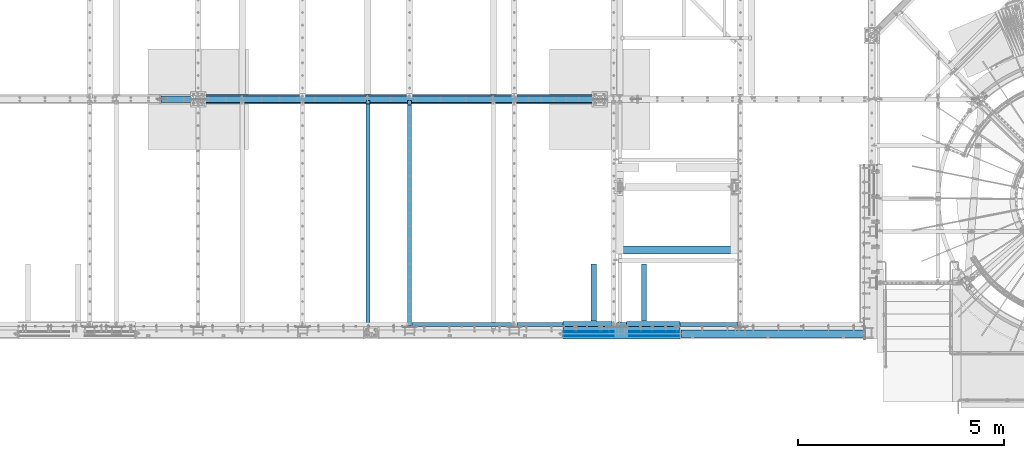
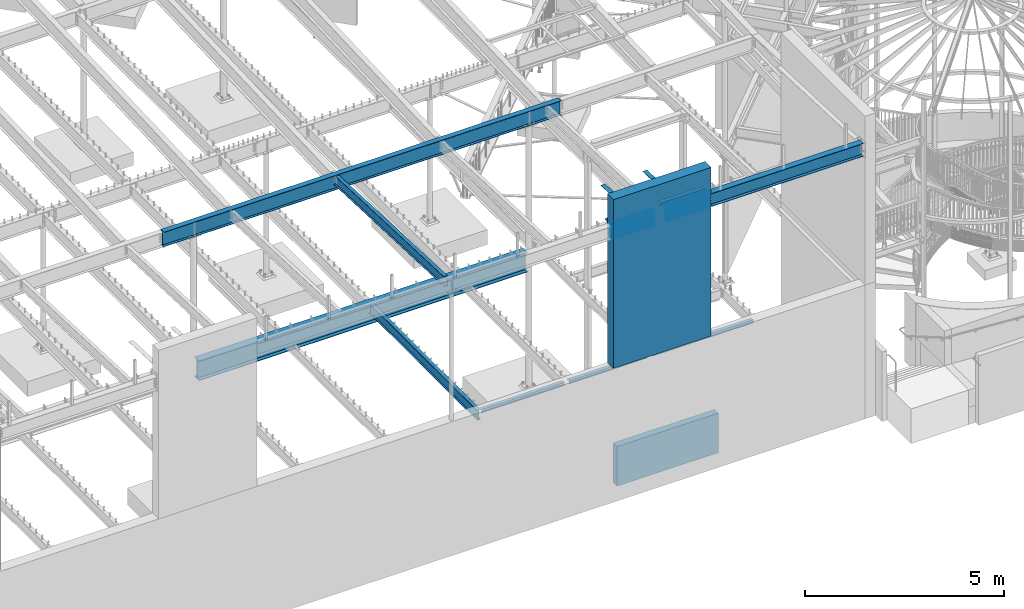
# One storey, part 314 of 975: 38 beams.
"""IFC2X3 building model written with IfcOpenShell, lengths in millimetres."""

from ifc_helpers import new_model, si_unit, frame, origin_with_axes, place, context, subcontext, project, spatial, faceted_brep, material, type_object, element, save


model = new_model("IFC2X3")

# Units and contexts
model_context = context("Model", 3, precision=1e-05, world=origin_with_axes())
body_context = subcontext(model_context, "Body", "Model", "MODEL_VIEW")
ifc_project = project(units=[si_unit("LENGTHUNIT", "METRE", prefix="MILLI"), si_unit("AREAUNIT", "SQUARE_METRE"), si_unit("VOLUMEUNIT", "CUBIC_METRE"), si_unit("MASSUNIT", "GRAM", prefix="KILO"), si_unit("TIMEUNIT", "SECOND"), si_unit("PLANEANGLEUNIT", "RADIAN"), si_unit("SOLIDANGLEUNIT", "STERADIAN"), si_unit("THERMODYNAMICTEMPERATUREUNIT", "DEGREE_CELSIUS"), si_unit("LUMINOUSINTENSITYUNIT", "LUMEN")], contexts=[model_context])

# Site, building, storey
site_placement = place(None, origin_with_axes())
site = spatial("IfcSite", under=ifc_project, at=site_placement, CompositionType="ELEMENT")
building_placement = place(site_placement, origin_with_axes())
building = spatial("IfcBuilding", under=site, at=building_placement, Name="Undefined", CompositionType="ELEMENT")
storey_placement = place(building_placement, origin_with_axes())
storey = spatial("IfcBuildingStorey", under=building, at=storey_placement, Name="Undefined", CompositionType="ELEMENT", Elevation=0.0)

# Beams
ifc_material_1 = material(Name="CONCRETE/5000")
beam_type_1 = type_object("IfcBeamType", PredefinedType="NOTDEFINED")
beam_1_placement = place(storey_placement, frame((23634.7000300942, 2163.76251138784, -609.6), z_axis=(0.0, 0.0, 1.0), x_axis=(1.0, 0.0, 0.0)))
element("IfcBeam", 1, at=beam_1_placement, inside=storey, type_object=beam_type_1, material=ifc_material_1, Name="WALL", context=body_context, shape_type="Brep", body=[
    faceted_brep([(0.0, 96.8375000000001, -609.6), (0.0, 96.8375000000001, 609.6), (2946.3999699058, 96.8375000000001, 609.6), (2946.3999699058, 96.8375000000001, -609.6), (0.0, -96.8375000000001, 609.6), (2946.3999699058, -96.8375000000001, 609.6), (0.0, -96.8375000000001, -609.6), (2946.3999699058, -96.8375000000001, -609.6)], [[[0, 1, 2, 3]], [[1, 4, 5, 2]], [[4, 6, 7, 5]], [[6, 0, 3, 7]], [[5, 7, 3, 2]], [[6, 4, 1, 0]]]),
])
ifc_material_2 = material(Name="STEEL/A36")
beam_type_2 = type_object("IfcBeamType", Name="L4X4X5/16", PredefinedType="NOTDEFINED")
beam_2_placement = place(storey_placement, frame((23634.7, 355.599999999998, 3886.2), z_axis=(0.0, 0.0, -1.0), x_axis=(1.0, 0.0, 0.0)))
element("IfcBeam", 2, at=beam_2_placement, inside=storey, type_object=beam_type_2, material=ifc_material_2, Name="LEDGER_ANGLE", ObjectType="L4X4X5/16", context=body_context, shape_type="Brep", body=[
    faceted_brep([(-1.90993887372315e-11, 50.8000000000002, -50.8), (2.00088834390044e-11, 50.8000000000002, 50.8), (2946.4, 50.8, 50.8000000000002), (2946.4, 50.8, -50.8000000000002), (2.00088834390044e-11, 42.8625000000002, 50.8), (2946.4, 42.8625, 50.8000000000002), (-1.63709046319127e-11, 42.8625000000002, -42.8625), (2946.4, 42.8625, -42.8625000000002), (-1.63709046319127e-11, -50.8000000000002, -42.8625), (2946.4, -50.8, -42.8625000000002), (-1.90993887372315e-11, -50.8000000000002, -50.8), (2946.4, -50.8, -50.8000000000002)], [[[0, 1, 2, 3]], [[1, 4, 5, 2]], [[4, 6, 7, 5]], [[6, 8, 9, 7]], [[8, 10, 11, 9]], [[10, 0, 3, 11]], [[5, 7, 9, 11, 3, 2]], [[10, 8, 6, 4, 1, 0]]]),
])
beam_3_placement = place(storey_placement, frame((21221.7, 355.599999999998, 3886.2), z_axis=(0.0, 0.0, -1.0), x_axis=(1.0, 0.0, 0.0)))
element("IfcBeam", 3, at=beam_3_placement, inside=storey, type_object=beam_type_2, material=ifc_material_2, Name="LEDGER_ANGLE", ObjectType="L4X4X5/16", context=body_context, shape_type="Brep", body=[
    faceted_brep([(-1.90993887372315e-11, 50.8000000000002, -50.8), (2.00088834390044e-11, 50.8000000000002, 50.8), (2286.0, 50.8, 50.8000000000002), (2286.0, 50.8, -50.8000000000002), (2.00088834390044e-11, 42.8625000000002, 50.8), (2286.0, 42.8625, 50.8000000000002), (-1.63709046319127e-11, 42.8625000000002, -42.8625), (2286.0, 42.8625, -42.8625000000002), (-1.63709046319127e-11, -50.8000000000002, -42.8625), (2286.0, -50.8, -42.8625000000002), (-1.90993887372315e-11, -50.8000000000002, -50.8), (2286.0, -50.8, -50.8000000000002)], [[[0, 1, 2, 3]], [[1, 4, 5, 2]], [[4, 6, 7, 5]], [[6, 8, 9, 7]], [[8, 10, 11, 9]], [[10, 0, 3, 11]], [[5, 7, 9, 11, 3, 2]], [[10, 8, 6, 4, 1, 0]]]),
])
beam_4_placement = place(storey_placement, frame((18681.7, 355.599999999998, 3886.2), z_axis=(0.0, 0.0, -1.0), x_axis=(1.0, 0.0, 0.0)))
element("IfcBeam", 4, at=beam_4_placement, inside=storey, type_object=beam_type_2, material=ifc_material_2, Name="LEDGER_ANGLE", ObjectType="L4X4X5/16", context=body_context, shape_type="Brep", body=[
    faceted_brep([(-1.90993887372315e-11, 50.8000000000002, -50.8), (2.00088834390044e-11, 50.8000000000002, 50.8), (2413.0, 50.8, 50.8000000000002), (2413.0, 50.8, -50.8000000000002), (2.00088834390044e-11, 42.8625000000002, 50.8), (2413.0, 42.8625, 50.8000000000002), (-1.63709046319127e-11, 42.8625000000002, -42.8625), (2413.0, 42.8625, -42.8625000000002), (-1.63709046319127e-11, -50.8000000000002, -42.8625), (2413.0, -50.8, -42.8625000000002), (-1.90993887372315e-11, -50.8000000000002, -50.8), (2413.0, -50.8, -50.8000000000002)], [[[0, 1, 2, 3]], [[1, 4, 5, 2]], [[4, 6, 7, 5]], [[6, 8, 9, 7]], [[8, 10, 11, 9]], [[10, 0, 3, 11]], [[5, 7, 9, 11, 3, 2]], [[10, 8, 6, 4, 1, 0]]]),
])
beam_type_3 = type_object("IfcBeamType", Name="L5X3X5/16", PredefinedType="NOTDEFINED")
beam_5_placement = place(storey_placement, frame((23523.5750053571, 368.300135935926, 8420.1), z_axis=(0.0, 1.0, 0.0), x_axis=(-0.999999999999998, 6.90000001668524e-08, 0.0)))
element("IfcBeam", 5, at=beam_5_placement, inside=storey, type_object=beam_type_3, material=ifc_material_2, Name="LEDGER_ANGLE", ObjectType="L5X3X5/16", context=body_context, shape_type="Brep", body=[
    faceted_brep([(5.0931703299284e-11, 38.0999999999999, -63.5000000000255), (-4.72937244921923e-11, 38.0999999999999, 63.5000000000182), (1187.44997470159, 38.1000000000004, 63.5000000000253), (1187.44997470171, 38.1000000000004, -63.4999999999751), (-3.63797880709171e-12, 30.1625000000404, 63.4999999999909), (1187.44997470159, 30.1625000000004, 63.5000000000253), (3.41060513164848e-12, 30.1624999999367, -55.5625000000091), (1187.4499747017, 30.1625000000004, -55.5624999999752), (2.27373675443232e-12, -38.1000000000313, -55.5624999999873), (1187.4499747017, -38.1000000000004, -55.5624999999752), (5.0931703299284e-11, -38.0999999999999, -63.5000000000255), (1187.44997470171, -38.1000000000004, -63.4999999999751)], [[[0, 1, 2, 3]], [[1, 4, 5, 2]], [[4, 6, 7, 5]], [[6, 8, 9, 7]], [[8, 10, 11, 9]], [[10, 0, 3, 11]], [[5, 7, 9, 11, 3, 2]], [[10, 8, 6, 4, 1, 0]]]),
])
beam_6_placement = place(storey_placement, frame((23085.4251517651, 1826.04386455261, 8358.9819720553), z_axis=(-0.999999999999998, 6.90000001668524e-08, 0.0), x_axis=(-8.29999998634476e-08, -0.999194714570452, 0.0401238379827506)))
element("IfcBeam", 6, at=beam_6_placement, inside=storey, type_object=beam_type_3, material=ifc_material_2, Name="ANGLE", ObjectType="L5X3X5/16", context=body_context, shape_type="Brep", body=[
    faceted_brep([(1395.30889729753, 38.1000000012609, 63.5000000006694), (1394.9901576922, 30.1625000012664, 63.5000000006712), (1394.99013793574, 30.1625000011627, -55.5624999993288), (1394.99013661864, 30.1625000322219, -63.4999999993288), (1395.30887618999, 38.1000000011518, -63.4999999993306), (1501.2669859932, 25.8948292101068, -55.562499999276), (1501.2669846761, 25.8948292629557, -63.499999999276), (1513.45074109103, 12.6953416428732, -55.5624999992651), (1513.45073977393, 12.695341695724, -63.4999999992651), (1511.42524778765, -38.0999999987016, -55.5624999992524), (1511.42524647055, -38.0999999987089, -63.4999999992524), (5.0931703299284e-11, -38.0999999999999, -63.5000000000255), (2.27373675443232e-12, -38.1000000000313, -55.5624999999873), (3.41060513164848e-12, 30.1624999999367, -55.5625000000091), (-3.63797880709171e-12, 30.1625000000404, 63.4999999999909), (-4.72937244921923e-11, 38.0999999999999, 63.5000000000182), (5.0931703299284e-11, 38.0999999999999, -63.5000000000255)], [[[0, 1, 2, 3, 4]], [[5, 6, 3, 2]], [[7, 8, 6, 5]], [[9, 10, 8, 7]], [[11, 12, 13, 14, 15, 16]], [[14, 13, 2, 1]], [[15, 14, 1, 0]], [[16, 15, 0, 4]], [[11, 16, 4, 3, 6, 8, 10]], [[12, 11, 10, 9]], [[2, 13, 12, 9, 7, 5]]]),
])
beam_7_placement = place(storey_placement, frame((24304.6248484384, 1826.04422887824, 8358.98197052349), z_axis=(-0.999999999999998, 6.90000001668524e-08, 0.0), x_axis=(-8.29999998634476e-08, -0.999194714570452, 0.0401238379827506)))
element("IfcBeam", 7, at=beam_7_placement, inside=storey, type_object=beam_type_3, material=ifc_material_2, Name="ANGLE", ObjectType="L5X3X5/16", context=body_context, shape_type="Brep", body=[
    faceted_brep([(1395.30914941058, 38.1000000010063, 63.4999999992615), (1394.99040990998, 30.1625000010026, 63.4999999992724), (1394.99040991799, 30.1625000011063, -55.5625000007276), (1394.99040991852, 30.1625000327458, -63.5000000007276), (1395.30914941901, 38.1000000011154, -63.5000000007385), (1501.26725800528, 25.8948300067641, -55.5625000007713), (1501.26725800582, 25.8948300067823, -63.5000000007713), (1513.45198580346, 12.6953037787844, -55.5625000007567), (1513.45198580399, 12.6953037788026, -63.5000000007567), (1511.42551577502, -38.0999999988144, -55.5625000006803), (1511.42551577556, -38.0999999988089, -63.5000000006803), (5.0931703299284e-11, -38.0999999999999, -63.5000000000255), (2.27373675443232e-12, -38.1000000000313, -55.5624999999873), (3.41060513164848e-12, 30.1624999999367, -55.5625000000091), (-3.63797880709171e-12, 30.1625000000404, 63.4999999999909), (-4.72937244921923e-11, 38.0999999999999, 63.5000000000182), (5.0931703299284e-11, 38.0999999999999, -63.5000000000255)], [[[0, 1, 2, 3, 4]], [[5, 6, 3, 2]], [[7, 8, 6, 5]], [[9, 10, 8, 7]], [[11, 12, 13, 14, 15, 16]], [[14, 13, 2, 1]], [[15, 14, 1, 0]], [[16, 15, 0, 4]], [[11, 16, 4, 3, 6, 8, 10]], [[12, 11, 10, 9]], [[2, 13, 12, 9, 7, 5]]]),
])
beam_8_placement = place(storey_placement, frame((25180.9250309127, 368.299999998704, 8420.1), z_axis=(0.0, 1.0, 0.0), x_axis=(-0.999999999999998, 6.90000001668524e-08, 0.0)))
element("IfcBeam", 8, at=beam_8_placement, inside=storey, type_object=beam_type_3, material=ifc_material_2, Name="LEDGER_ANGLE", ObjectType="L5X3X5/16", context=body_context, shape_type="Brep", body=[
    faceted_brep([(5.0931703299284e-11, 38.0999999999999, -63.5000000000255), (-4.72937244921923e-11, 38.0999999999999, 63.5000000000182), (1301.75002529847, 38.1000000000004, 63.4999999999727), (1301.75002529835, 38.1000000000004, -63.5000000000277), (-3.63797880709171e-12, 30.1625000000404, 63.4999999999909), (1301.75002529847, 30.1625000000004, 63.4999999999727), (3.41060513164848e-12, 30.1624999999367, -55.5625000000091), (1301.75002529836, 30.1625000000004, -55.5625000000277), (2.27373675443232e-12, -38.1000000000313, -55.5624999999873), (1301.75002529836, -38.1000000000004, -55.5625000000277), (5.0931703299284e-11, -38.0999999999999, -63.5000000000255), (1301.75002529835, -38.1000000000004, -63.5000000000277)], [[[0, 1, 2, 3]], [[1, 4, 5, 2]], [[4, 6, 7, 5]], [[6, 8, 9, 7]], [[8, 10, 11, 9]], [[10, 0, 3, 11]], [[5, 7, 9, 11, 3, 2]], [[10, 8, 6, 4, 1, 0]]]),
])
ifc_material_3 = material(Name="STEEL/A496")
beam_type_4 = type_object("IfcBeamType", Name="#6 DBA", PredefinedType="NOTDEFINED")
for number, where, z_axis, x_axis, name in (
    (9, (25161.8750036894, 177.800001625287, 8389.94743098933), (0.0, 1.0, 0.0), (-0.999999999999998, 6.90000001668524e-08, 0.0), "ROD"),
    (10, (25161.8750032832, 76.2000016252808, 8389.9474310055), (0.0, 1.0, 0.0), (-0.999999999999998, 6.90000001668524e-08, 0.0), "ROD"),
    (11, (25161.8750036894, 177.800001607478, 8301.04744311368), (0.0, 1.0, 0.0), (-0.999999999999998, 6.90000001668524e-08, 0.0), "ROD"),
    (12, (25161.8750032832, 76.2000016074719, 8301.04744312985), (0.0, 1.0, 0.0), (-0.999999999999998, 6.90000001668524e-08, 0.0), "ROD"),
    (13, (25161.8750036894, 177.800001589665, 8212.14745523802), (0.0, 1.0, 0.0), (-0.999999999999998, 6.90000001668524e-08, 0.0), "ROD"),
    (14, (25161.8750032832, 76.2000015896593, 8212.14745525419), (0.0, 1.0, 0.0), (-0.999999999999998, 6.90000001668524e-08, 0.0), "ROD"),
    (15, (25161.8750036894, 177.800001571856, 8123.24746736236), (0.0, 1.0, 0.0), (-0.999999999999998, 6.90000001668524e-08, 0.0), "ROD"),
    (16, (25161.8750032832, 76.2000015718503, 8123.24746737853), (0.0, 1.0, 0.0), (-0.999999999999998, 6.90000001668524e-08, 0.0), "ROD"),
    (17, (25161.8750036894, 177.800001554044, 8034.3474794867), (0.0, 1.0, 0.0), (-0.999999999999998, 6.90000001668524e-08, 0.0), "ROD"),
    (18, (25161.8750032832, 76.2000015540377, 8034.34747950287), (0.0, 1.0, 0.0), (-0.999999999999998, 6.90000001668524e-08, 0.0), "ROD"),
    (19, (25161.8750036894, 177.800001643099, 8478.84741886499), (0.0, 1.0, 0.0), (-0.999999999999998, 6.90000001668524e-08, 0.0), "ROD"),
    (20, (25161.8750032832, 76.2000016430934, 8478.84741888116), (0.0, 1.0, 0.0), (-0.999999999999998, 6.90000001668524e-08, 0.0), "ROD"),
    (21, (22355.1750195517, 76.1999983747104, 8389.9475019974), (0.0, -1.0, 0.0), (1.0, 0.0, 0.0), "ROD"),
    (22, (22355.1750199578, 177.799998374716, 8389.94750201357), (0.0, -1.0, 0.0), (1.0, 0.0, 0.0), "ROD"),
    (23, (22355.1750195517, 76.1999983925194, 8301.04751412175), (0.0, -1.0, 0.0), (1.0, 0.0, 0.0), "ROD"),
    (24, (22355.1750199578, 177.799998392525, 8301.04751413792), (0.0, -1.0, 0.0), (1.0, 0.0, 0.0), "ROD"),
    (25, (22355.1750195517, 76.1999984103319, 8212.14752624609), (0.0, -1.0, 0.0), (1.0, 0.0, 0.0), "ROD"),
    (26, (22355.1750199578, 177.799998410338, 8212.14752626226), (0.0, -1.0, 0.0), (1.0, 0.0, 0.0), "ROD"),
    (27, (22355.1750195517, 76.1999984281409, 8123.24753837043), (0.0, -1.0, 0.0), (1.0, 0.0, 0.0), "ROD"),
    (28, (22355.1750199578, 177.799998428147, 8123.2475383866), (0.0, -1.0, 0.0), (1.0, 0.0, 0.0), "ROD"),
    (29, (22355.1750195517, 76.1999984459535, 8034.34755049477), (0.0, -1.0, 0.0), (1.0, 0.0, 0.0), "ROD"),
    (30, (22355.1750199578, 177.799998445959, 8034.34755051095), (0.0, -1.0, 0.0), (1.0, 0.0, 0.0), "ROD"),
    (31, (22355.1949048169, 76.1999983552473, 8478.84748987306), (0.0, -1.0, 0.0), (1.0, 0.0, 0.0), "ROD"),
    (32, (22355.194905223, 177.799998355253, 8478.84748988923), (0.0, -1.0, 0.0), (1.0, 0.0, 0.0), "ROD"),
):
    element("IfcBeam", number, at=place(storey_placement, frame(where, z_axis=z_axis, x_axis=x_axis)), inside=storey, type_object=beam_type_4, material=ifc_material_3, Name=name, ObjectType="#6 DBA", context=body_context, shape_type="Brep", body=[
        faceted_brep([(0.0, -6.34999999998763, -3.63797880709171e-12), (0.0, -4.49012806052269, -4.49012806054634), (1219.19983372321, -4.49012806053543, -4.49012805836537), (1219.19983372321, -6.35000000000036, 2.16823536902666e-09), (0.0, 7.27595761418343e-12, -6.35000000000764), (1219.19983372321, 0.0, -6.34999999783395), (0.0, 4.49012806053724, -4.49012806053906), (1219.19983372321, 4.49012806053543, -4.49012805836537), (0.0, 6.34999999999491, 5.45696821063757e-12), (1219.19983372321, 6.35000000000036, 2.16823536902666e-09), (0.0, 4.49012806052633, 4.49012806054634), (1219.19983372321, 4.49012806053543, 4.49012806270184), (0.0, 0.0, 6.35000000000764), (1219.19983372321, 0.0, 6.35000000216678), (0.0, -4.49012806053361, 4.49012806053543), (1219.19983372321, -4.49012806053543, 4.49012806270184)], [[[0, 1, 2, 3]], [[1, 4, 5, 2]], [[4, 6, 7, 5]], [[6, 8, 9, 7]], [[8, 10, 11, 9]], [[10, 12, 13, 11]], [[12, 14, 15, 13]], [[14, 0, 3, 15]], [[5, 7, 9, 11, 13, 15, 3, 2]], [[14, 12, 10, 8, 6, 4, 1, 0]]]),
    ])
ifc_material_4 = material(Name="STEEL/A992")
beam_type_5 = type_object("IfcBeamType", Name="W12X14", PredefinedType="NOTDEFINED")
beam_9_placement = place(storey_placement, frame((17605.375, 120.948825633107, 8307.50894703329), z_axis=(0.0, 0.0401238250036801, 0.999194715091645), x_axis=(0.0, 0.999194715091645, -0.0401238250036801)))
element("IfcBeam", 33, at=beam_9_placement, inside=storey, type_object=beam_type_5, material=ifc_material_4, Name="BEAM", ObjectType="W12X14", context=body_context, shape_type="Brep", body=[
    faceted_brep([(37.0520047015657, -2.38124999999854, -119.062500000143), (37.0520047015657, 2.38124999999854, -119.062500000143), (115.114860630816, 2.38124999999854, -119.062500000046), (115.114860630816, -2.38124999999854, -119.062500000046), (119.974940148861, 2.38124999999854, -120.029229922632), (119.974940148861, -2.38124999999854, -120.029229922632), (124.095116617013, 2.38124999999854, -122.78224382311), (124.095116617013, -2.38124999999854, -122.78224382311), (126.84813051749, 2.38124999999854, -126.902420291266), (126.84813051749, -2.38124999999854, -126.902420291266), (127.814860440076, -2.38124999999854, -131.762499809317), (127.814860440076, 2.38124999999854, -131.762499809317), (127.814860440082, 2.38124999999854, -144.462500000007), (127.814860440081, 50.7999999999993, -144.462500000007), (127.814860440083, 50.7999999999993, -150.812500000009), (127.814860440083, -50.7999999999993, -150.812500000009), (127.814860440082, -50.7999999999993, -144.462500000007), (127.814860440082, -2.38124999999854, -144.462500000007), (5581.66024242718, 50.7999999999993, 144.462500002061), (5581.66024242718, 2.38124999999854, 144.462500002061), (127.814860440073, 2.38124999999854, 144.4625000001), (127.814860440073, 50.7999999999993, 144.4625000001), (115.114860630788, -2.38124999999854, 119.062500000273), (115.114860630788, 2.38124999999854, 119.062500000273), (27.4898185884682, 2.38124999999854, 119.062500000271), (27.4898185884682, -2.38124999999854, 119.062500000271), (119.974940148833, -2.38124999999854, 120.029229922864), (119.974940148833, 2.38124999999854, 120.029229922864), (124.095116616988, -2.38124999999854, 122.782243823349), (124.095116616988, 2.38124999999854, 122.782243823349), (126.848130517467, -2.38124999999854, 126.902420291508), (126.848130517467, 2.38124999999854, 126.902420291508), (127.814860440057, -2.38124999999854, 131.76249980956), (127.814860440057, 2.38124999999854, 131.76249980956), (5581.66024242718, -50.7999999999993, 150.812500002065), (5581.66024242718, 50.7999999999993, 150.812500002065), (127.814860440071, 50.7999999999993, 150.812500000104), (127.814860440071, -50.7999999999993, 150.812499810841), (5581.66024242718, -50.7999999999993, 144.462500002061), (127.814860440073, -50.7999999999993, 144.4625000001), (5581.66024242718, -2.38124999999854, 144.462500002061), (127.814860440073, -2.38124999999854, 144.4625000001), (5581.66024242718, -2.38124999999854, 131.762499841927), (5581.66024242718, 2.38124999999854, 131.762499841927), (5582.62697234977, -2.38124999999854, 126.902420323875), (5582.62697234977, 2.38124999999854, 126.902420323875), (5585.37998625025, -2.38124999999854, 122.78224385572), (5585.37998625025, 2.38124999999854, 122.78224385572), (5589.5001627184, -2.38124999999854, 120.029229955242), (5589.5001627184, 2.38124999999854, 120.029229955242), (5594.36024223645, -2.38124999999854, 119.062500032656), (5594.36024223645, 2.38124999999854, 119.062500032656), (5672.42309816582, -2.38124999999854, 119.062500032685), (5672.42309816582, 2.38124999999854, 119.062500032685), (5683.00525079886, -2.38124999999854, -144.46249999801), (5683.00525079886, -50.7999999999993, -144.46249999801), (5683.26024242854, -50.7999999999993, -150.812499998011), (5683.26024242854, 50.7999999999993, -150.812499998011), (5683.00525079886, 50.7999999999993, -144.46249999801), (5683.00525079886, 2.38124999999854, -144.46249999801)], [[[0, 1, 2, 3]], [[3, 2, 4, 5]], [[5, 4, 6, 7]], [[7, 6, 8, 9]], [[10, 11, 12, 13, 14, 15, 16, 17]], [[9, 8, 11, 10]], [[18, 19, 20, 21]], [[22, 23, 24, 25]], [[26, 27, 23, 22]], [[28, 29, 27, 26]], [[30, 31, 29, 28]], [[32, 33, 31, 30]], [[34, 35, 36, 37]], [[38, 34, 37, 39]], [[40, 38, 39, 41]], [[37, 36, 21, 20, 33, 32, 41, 39]], [[35, 18, 21, 36]], [[34, 38, 40, 42, 43, 19, 18, 35]], [[44, 45, 43, 42]], [[46, 47, 45, 44]], [[48, 49, 47, 46]], [[50, 51, 49, 48]], [[52, 53, 51, 50]], [[54, 55, 56, 57, 58, 59, 53, 52]], [[55, 54, 17, 16]], [[56, 55, 16, 15]], [[57, 56, 15, 14]], [[58, 57, 14, 13]], [[59, 58, 13, 12]], [[6, 4, 2, 1, 24, 23, 27, 29, 31, 33, 20, 19, 43, 45, 47, 49, 51, 53, 59, 12, 11, 8]], [[25, 24, 1, 0]], [[54, 52, 50, 48, 46, 44, 42, 40, 41, 32, 30, 28, 26, 22, 25, 0, 3, 5, 7, 9, 10, 17]]]),
])
beam_type_6 = type_object("IfcBeamType", Name="W16X36", PredefinedType="NOTDEFINED")
beam_10_placement = place(storey_placement, frame((25180.9250127, 127.0, 8256.5875), z_axis=(0.0, 0.0, -1.0), x_axis=(1.0, 0.0, 0.0)))
element("IfcBeam", 34, at=beam_10_placement, inside=storey, type_object=beam_type_6, material=ifc_material_4, Name="BEAM", ObjectType="W16X36", context=body_context, shape_type="Brep", body=[
    faceted_brep([(25.3999999999996, -88.9, -201.612499999999), (25.3999999999996, 88.9, -201.612499999999), (4448.17495059492, 88.9, -201.612499999999), (4448.17495059492, -88.9, -201.612499999999), (25.3999999999996, -88.9, -190.5), (25.3999999999996, -3.96875, -190.5), (25.3999999999996, -3.96875, 190.5), (25.3999999999996, -88.9, 190.5), (25.3999999999996, -88.9, 201.6125), (25.3999999999996, 88.9, 201.6125), (25.3999999999996, 88.9, 190.5), (25.3999999999996, 3.96875, 190.5), (25.3999999999996, 3.96875, -190.5), (25.3999999999996, 88.9, -190.5), (4448.17495059492, -88.9, -190.5), (4448.17495059492, -3.96875, -190.5), (4448.17495059492, -3.96875, 190.5), (4448.17495059492, -88.9, 190.5), (4448.17495059492, -88.9, 201.6125), (4448.17495059492, 88.9, 201.6125), (4448.17495059492, 88.9, 190.5), (4448.17495059492, 3.96875, 190.5), (4448.17495059492, 3.96875, -190.5), (4448.17495059492, 88.9, -190.5)], [[[0, 1, 2, 3]], [[0, 4, 5, 6, 7, 8, 9, 10, 11, 12, 13, 1]], [[5, 4, 14, 15]], [[6, 5, 15, 16]], [[7, 6, 16, 17]], [[8, 7, 17, 18]], [[9, 8, 18, 19]], [[10, 9, 19, 20]], [[11, 10, 20, 21]], [[12, 11, 21, 22]], [[13, 12, 22, 23]], [[1, 13, 23, 2]], [[22, 21, 20, 19, 18, 17, 16, 15, 14, 3, 2, 23]], [[4, 0, 3, 14]]]),
])
beam_type_7 = type_object("IfcBeamType", Name="W18X35", PredefinedType="NOTDEFINED")
beam_11_placement = place(storey_placement, frame((12573.0, 5819.775, 8004.175), z_axis=(0.0, 0.0, 1.0), x_axis=(1.0, 0.0, 0.0)))
element("IfcBeam", 35, at=beam_11_placement, inside=storey, type_object=beam_type_7, material=ifc_material_4, Name="BEAM", ObjectType="W18X35", context=body_context, shape_type="Brep", body=[
    faceted_brep([(11571.6845161776, -3.96875, 213.915499496458), (11571.6845161776, 3.96875, 213.915499496458), (11571.2875312948, 3.96875, 214.312499999999), (11571.2875312948, 76.1999999999998, 214.312499999999), (11560.1754685373, 76.1999999999998, 225.425), (11560.1754685373, -76.1999999999998, 225.425), (11571.2875312948, -76.1999999999998, 214.312499999999), (11571.2875312948, -3.96875, 214.312499999999), (14.287031462678, -76.1999999999998, 225.425), (14.287031462678, 76.1999999999998, 225.425), (3.17496870515606, 76.1999999999998, 214.312499999999), (3.17496870515606, 3.96875, 214.312499999999), (2.77798382235414, 3.96875, 213.915499496458), (2.77798382235414, -3.96875, 213.915499496458), (3.17496870515606, -3.96875, 214.312499999999), (3.17496870515606, -76.1999999999998, 214.312499999999), (22.2250007629409, 3.96875, 213.915499496458), (22.2250007629409, -3.96875, 213.915499496458), (40.7122683048001, 3.96875, 203.575605287907), (40.7122683048001, -3.96875, 203.575605287907), (44.8249534620081, 3.96875, 198.997422721183), (44.8249534620081, -3.96875, 198.997422721183), (45.2798117862694, 3.96875, 192.860074863892), (45.2798117862694, -3.96875, 192.860074863892), (41.8869600345242, 3.96875, 187.725633140859), (41.8869600345242, -3.96875, 187.725633140859), (36.0627638298283, 3.96875, 185.737499999999), (36.0627638298283, -3.96875, 185.737499999999), (6.34999999999854, 3.96875, 185.737499999999), (6.34999999999854, -3.96875, 185.737499999999), (6.34999999999854, 3.96875, -185.7375), (6.34999999999854, -3.96875, -185.7375), (47.9687625480874, 3.96875, -185.7375), (47.9687625480874, -3.96875, -185.7375), (53.7929587527833, 3.96875, -187.72563314086), (53.7929587527833, -3.96875, -187.72563314086), (57.1858105045285, 3.96875, -192.860074863893), (57.1858105045285, -3.96875, -192.860074863893), (56.7309521802672, 3.96875, -198.997422721185), (56.7309521802672, -3.96875, -198.997422721185), (52.6182670230592, 3.96875, -203.575605287907), (52.6182670230592, -3.96875, -203.575605287907), (34.1309994812, 3.96875, -213.91549949646), (34.1309994812, -3.96875, -213.91549949646), (14.6840158801024, 3.96875, -213.91549949646), (14.6840158801024, -3.96875, -213.91549949646), (14.2870309973041, 3.96875, -214.3125), (14.2870309973041, 76.1999999999998, -214.3125), (3.17496823977854, 76.1999999999998, -225.425), (3.17496823977854, -76.1999999999998, -225.425), (14.2870309973041, -76.1999999999998, -214.3125), (14.2870309973041, -3.96875, -214.3125), (11560.1754690027, 3.96875, -214.3125), (11560.1754690027, 76.1999999999998, -214.3125), (11571.2875317602, 76.1999999999998, -225.425), (11571.2875317602, -76.1999999999998, -225.425), (11560.1754690027, -76.1999999999998, -214.3125), (11560.1754690027, -3.96875, -214.3125), (11559.7784841199, 3.96875, -213.91549949646), (11559.7784841199, -3.96875, -213.91549949646), (11540.3315005188, 3.96875, -213.91549949646), (11540.3315005188, -3.96875, -213.91549949646), (11521.8442329769, 3.96875, -203.575605287907), (11521.8442329769, -3.96875, -203.575605287907), (11517.7315478197, 3.96875, -198.997422721185), (11517.7315478197, -3.96875, -198.997422721185), (11517.2766894955, 3.96875, -192.860074863893), (11517.2766894955, -3.96875, -192.860074863893), (11520.6695412472, 3.96875, -187.72563314086), (11520.6695412472, -3.96875, -187.72563314086), (11526.4937374519, 3.96875, -185.7375), (11526.4937374519, -3.96875, -185.7375), (11568.1125, 3.96875, -185.7375), (11568.1125, -3.96875, -185.7375), (11568.1125, -3.96875, 185.737499999999), (11568.1125, 3.96875, 185.737499999999), (11538.3997361702, 3.96875, 185.737499999999), (11538.3997361702, -3.96875, 185.737499999999), (11532.5755399655, 3.96875, 187.725633140859), (11532.5755399655, -3.96875, 187.725633140859), (11529.1826882137, 3.96875, 192.860074863892), (11529.1826882137, -3.96875, 192.860074863892), (11529.637546538, 3.96875, 198.997422721183), (11529.637546538, -3.96875, 198.997422721183), (11533.7502316952, 3.96875, 203.575605287907), (11533.7502316952, -3.96875, 203.575605287907), (11552.2374992371, 3.96875, 213.915499496458), (11552.2374992371, -3.96875, 213.915499496458)], [[[0, 1, 2, 3, 4, 5, 6, 7]], [[8, 9, 10, 11, 12, 13, 14, 15]], [[16, 17, 13, 12]], [[17, 16, 18, 19]], [[19, 18, 20, 21]], [[21, 20, 22, 23]], [[23, 22, 24, 25]], [[25, 24, 26, 27]], [[27, 26, 28, 29]], [[29, 28, 30, 31]], [[32, 33, 31, 30]], [[33, 32, 34, 35]], [[35, 34, 36, 37]], [[37, 36, 38, 39]], [[39, 38, 40, 41]], [[41, 40, 42, 43]], [[43, 42, 44, 45]], [[45, 44, 46, 47, 48, 49, 50, 51]], [[47, 46, 52, 53]], [[48, 47, 53, 54]], [[49, 48, 54, 55]], [[50, 49, 55, 56]], [[51, 50, 56, 57]], [[55, 54, 53, 52, 58, 59, 57, 56]], [[60, 61, 59, 58]], [[61, 60, 62, 63]], [[63, 62, 64, 65]], [[65, 64, 66, 67]], [[67, 66, 68, 69]], [[69, 68, 70, 71]], [[71, 70, 72, 73]], [[74, 73, 72, 75]], [[76, 77, 74, 75]], [[77, 76, 78, 79]], [[79, 78, 80, 81]], [[81, 80, 82, 83]], [[83, 82, 84, 85]], [[85, 84, 86, 87]], [[14, 13, 17, 19, 21, 23, 25, 27, 29, 31, 33, 35, 37, 39, 41, 43, 45, 51, 57, 59, 61, 63, 65, 67, 69, 71, 73, 74, 77, 79, 81, 83, 85, 87, 0, 7]], [[15, 14, 7, 6]], [[8, 15, 6, 5]], [[9, 8, 5, 4]], [[10, 9, 4, 3]], [[11, 10, 3, 2]], [[86, 84, 82, 80, 78, 76, 75, 72, 70, 68, 66, 64, 62, 60, 58, 52, 46, 44, 42, 40, 38, 36, 34, 32, 30, 28, 26, 24, 22, 20, 18, 16, 12, 11, 2, 1]], [[87, 86, 1, 0]]]),
])
beam_type_8 = type_object("IfcBeamType", PredefinedType="NOTDEFINED")
beam_12_placement = place(storey_placement, frame((22336.1250126491, 152.400236117105, 6705.6), z_axis=(0.0, 0.0, 1.0), x_axis=(1.0, 0.0, 0.0)))
element("IfcBeam", 36, at=beam_12_placement, inside=storey, type_object=beam_type_8, material=ifc_material_1, Name="WALL", context=body_context, shape_type="Brep", body=[
    faceted_brep([(0.0, 152.400000000001, -2590.8), (0.0, 152.400000000001, 2590.8), (2844.80000000014, 152.399999999991, 2590.8), (2844.80000000014, 152.399999999991, -2590.8), (0.0, -152.400000000001, 2590.8), (2844.8, -152.40000000001, 2590.8), (0.0, -152.400000000001, -2590.8), (2844.8, -152.40000000001, -2590.8)], [[[0, 1, 2, 3]], [[1, 4, 5, 2]], [[4, 6, 7, 5]], [[6, 0, 3, 7]], [[5, 7, 3, 2]], [[6, 4, 1, 0]]]),
])
beam_type_9 = type_object("IfcBeamType", Name="W12X19", PredefinedType="NOTDEFINED")
beam_13_placement = place(storey_placement, frame((18618.2, 114.300000000004, 3783.0125), z_axis=(0.0, 0.0, 1.0), x_axis=(0.0, 1.0, 0.0)))
element("IfcBeam", 37, at=beam_13_placement, inside=storey, type_object=beam_type_9, material=ifc_material_4, Name="BEAM", ObjectType="W12X19", context=body_context, shape_type="Brep", body=[
    faceted_brep([(215.899999999996, -3.17499999999927, -144.4625), (215.899999999996, -50.7999999999993, -144.4625), (5674.51874999999, -50.7999999999993, -144.4625), (5674.51874999999, -3.17499999999927, -144.4625), (215.899999999996, -50.7999999999993, -153.9875), (5674.51874999999, -50.7999999999993, -153.9875), (215.899999999996, 50.7999999999993, -153.9875), (5674.51874999999, 50.7999999999993, -153.9875), (215.899999999996, 50.7999999999993, -144.4625), (215.899999999996, 3.17499999999927, -144.4625), (5674.51874999999, 3.17499999999927, -144.4625), (5674.51874999999, 50.7999999999993, -144.4625), (5674.51874999999, 3.17499999999927, 128.5875), (5674.51874999999, -3.17499999999927, 128.5875), (215.899999999996, -3.17499999999927, 144.4625), (215.899999999996, -50.7999999999993, 144.4625), (215.899999999996, -50.7999999999993, 153.9875), (215.899999999996, 50.7999999999993, 153.9875), (215.899999999996, 50.7999999999993, 144.4625), (215.899999999996, 3.17499999999927, 144.4625), (5566.56874999999, 50.7999999999993, 144.4625), (5566.56874999999, 3.17499999999927, 144.4625), (5566.56874999999, 3.17499999999927, 141.287499809265), (5567.53547992258, 3.17499999999927, 136.42742029122), (5570.28849382306, 3.17499999999927, 132.307243823066), (5574.40867029121, 3.17499999999927, 129.554229922588), (5579.26874980926, 3.17499999999927, 128.5875), (5567.53547992258, -3.17499999999927, 136.42742029122), (5566.56874999999, -3.17499999999927, 141.287499809265), (5570.28849382306, -3.17499999999927, 132.307243823066), (5574.40867029121, -3.17499999999927, 129.554229922588), (5579.26874980926, -3.17499999999927, 128.5875), (5566.56874999999, -3.17499999999927, 144.4625), (5566.56874999999, -50.7999999999993, 144.4625), (5566.56874999999, -50.7999999999993, 153.9875), (5566.56874999999, 50.7999999999993, 153.9875)], [[[0, 1, 2, 3]], [[1, 4, 5, 2]], [[4, 6, 7, 5]], [[8, 9, 10, 11]], [[3, 2, 5, 7, 11, 10, 12, 13]], [[6, 8, 11, 7]], [[4, 1, 0, 14, 15, 16, 17, 18, 19, 9, 8, 6]], [[19, 18, 20, 21]], [[10, 9, 19, 21, 22, 23, 24, 25, 26, 12]], [[27, 23, 22, 28]], [[29, 24, 23, 27]], [[30, 25, 24, 29]], [[31, 26, 25, 30]], [[13, 12, 26, 31]], [[30, 29, 27, 28, 32, 14, 0, 3, 13, 31]], [[15, 14, 32, 33]], [[16, 15, 33, 34]], [[17, 16, 34, 35]], [[18, 17, 35, 20]], [[34, 33, 32, 28, 22, 21, 20, 35]]]),
])
beam_type_10 = type_object("IfcBeamType", Name="W24X68", PredefinedType="NOTDEFINED")
beam_14_placement = place(storey_placement, frame((13487.4, 5819.775, 3635.375), z_axis=(0.0, 0.0, 1.0), x_axis=(1.0, 0.0, 0.0)))
element("IfcBeam", 38, at=beam_14_placement, inside=storey, type_object=beam_type_10, material=ifc_material_4, Name="BEAM", ObjectType="W24X68", context=body_context, shape_type="Brep", body=[
    faceted_brep([(96.9009999999998, 114.3, -301.625), (96.9009999999998, 114.3, -287.3375), (9648.7615, 114.3, -287.3375), (9648.7615, 114.3, -301.625), (96.9009999999998, 5.55624999999964, -287.3375), (9648.7615, 5.55624999999964, -287.3375), (96.9009999999998, 5.55624999999964, 287.3375), (9648.7615, 5.55624999999964, 287.3375), (96.9009999999998, 114.3, 287.3375), (9648.7615, 114.3, 287.3375), (96.9009999999998, 114.3, 301.625), (9648.7615, 114.3, 301.625), (96.9009999999998, -114.3, 301.625), (9648.7615, -114.3, 301.625), (96.9009999999998, -114.3, 287.3375), (9648.7615, -114.3, 287.3375), (96.9009999999998, -5.55624999999964, 287.3375), (9648.7615, -5.55624999999964, 287.3375), (96.9009999999998, -5.55624999999964, -287.3375), (9648.7615, -5.55624999999964, -287.3375), (96.9009999999998, -114.3, -287.3375), (9648.7615, -114.3, -287.3375), (96.9009999999998, -114.3, -301.625), (9648.7615, -114.3, -301.625)], [[[0, 1, 2, 3]], [[1, 4, 5, 2]], [[4, 6, 7, 5]], [[6, 8, 9, 7]], [[8, 10, 11, 9]], [[10, 12, 13, 11]], [[12, 14, 15, 13]], [[14, 16, 17, 15]], [[16, 18, 19, 17]], [[18, 20, 21, 19]], [[20, 22, 23, 21]], [[22, 0, 3, 23]], [[5, 7, 9, 11, 13, 15, 17, 19, 21, 23, 3, 2]], [[22, 20, 18, 16, 14, 12, 10, 8, 6, 4, 1, 0]]]),
])

save(model, "model.ifc")
